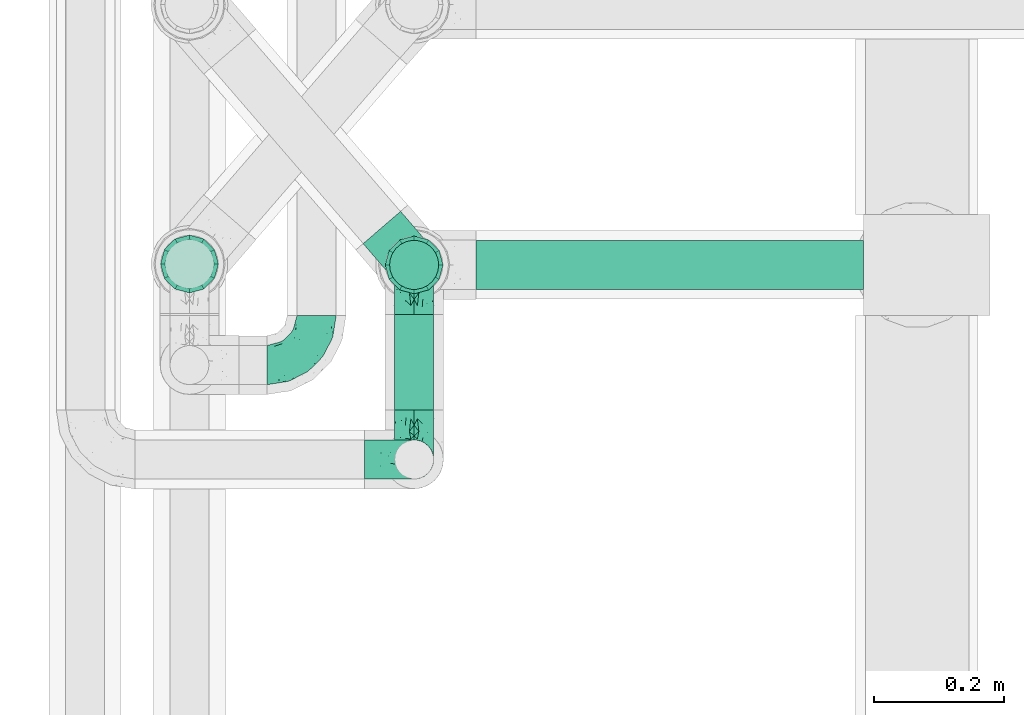
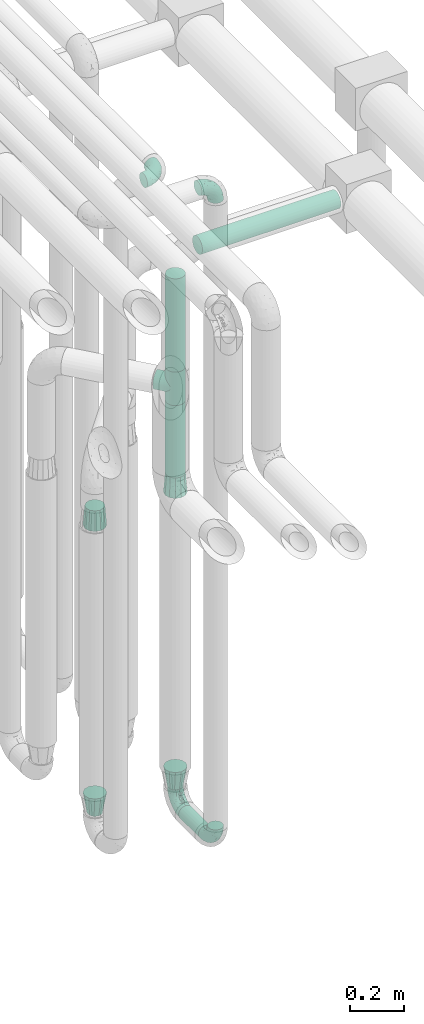
# One storey, part 608 of 827: 9 flow fittings, 4 flow segments.
"""IFC2X3 building model written with IfcOpenShell, lengths in millimetres."""

from ifc_helpers import new_model, entity, si_unit, converted_unit, derived_unit, direction, frame, origin, origin_2d_with_axis, place, context, subcontext, project, spatial, circle, extrude, faceted_brep, source, transform, mapped, material, type_object, type_shapes, element, save


model = new_model("IFC2X3")

# Units and contexts
model_context = context("Model", 3, precision=0.01, world=origin(), true_north=direction((6.12303176911189e-17, 1.0)))
body_context = subcontext(model_context, "Body", "Model", "MODEL_VIEW")
ifc_project = project(units=[si_unit("LENGTHUNIT", "METRE", prefix="MILLI"), si_unit("AREAUNIT", "SQUARE_METRE"), si_unit("VOLUMEUNIT", "CUBIC_METRE"), converted_unit("PLANEANGLEUNIT", "DEGREE", entity("IfcRatioMeasure", 0.0174532925199433), si_unit("PLANEANGLEUNIT", "RADIAN"), dimensions=[0, 0, 0, 0, 0, 0, 0]), si_unit("MASSUNIT", "GRAM", prefix="KILO"), derived_unit("MASSDENSITYUNIT", [(si_unit("MASSUNIT", "GRAM", prefix="KILO"), 1), (si_unit("LENGTHUNIT", "METRE"), -3)]), derived_unit("MOMENTOFINERTIAUNIT", [(si_unit("LENGTHUNIT", "METRE"), 4)]), si_unit("TIMEUNIT", "SECOND"), si_unit("FREQUENCYUNIT", "HERTZ"), si_unit("THERMODYNAMICTEMPERATUREUNIT", "DEGREE_CELSIUS"), derived_unit("THERMALTRANSMITTANCEUNIT", [(si_unit("MASSUNIT", "GRAM", prefix="KILO"), 1), (si_unit("THERMODYNAMICTEMPERATUREUNIT", "KELVIN"), -1), (si_unit("TIMEUNIT", "SECOND"), -3)]), derived_unit("VOLUMETRICFLOWRATEUNIT", [(si_unit("LENGTHUNIT", "METRE"), 3), (si_unit("TIMEUNIT", "SECOND"), -1)]), derived_unit("MASSFLOWRATEUNIT", [(si_unit("MASSUNIT", "GRAM", prefix="KILO"), 1), (si_unit("TIMEUNIT", "SECOND"), -1)]), derived_unit("ROTATIONALFREQUENCYUNIT", [(si_unit("TIMEUNIT", "SECOND"), -1)]), si_unit("ELECTRICCURRENTUNIT", "AMPERE"), si_unit("ELECTRICVOLTAGEUNIT", "VOLT"), si_unit("POWERUNIT", "WATT"), si_unit("FORCEUNIT", "NEWTON", prefix="KILO"), si_unit("ILLUMINANCEUNIT", "LUX"), si_unit("LUMINOUSFLUXUNIT", "LUMEN"), si_unit("LUMINOUSINTENSITYUNIT", "CANDELA"), derived_unit("USERDEFINED", [(si_unit("MASSUNIT", "GRAM", prefix="KILO"), -1), (si_unit("LENGTHUNIT", "METRE"), -2), (si_unit("TIMEUNIT", "SECOND"), 3), (si_unit("LUMINOUSFLUXUNIT", "LUMEN"), 1)]), derived_unit("LINEARVELOCITYUNIT", [(si_unit("LENGTHUNIT", "METRE"), 1), (si_unit("TIMEUNIT", "SECOND"), -1)]), si_unit("PRESSUREUNIT", "PASCAL"), derived_unit("USERDEFINED", [(si_unit("LENGTHUNIT", "METRE"), -2), (si_unit("MASSUNIT", "GRAM", prefix="KILO"), 1), (si_unit("TIMEUNIT", "SECOND"), -2)]), derived_unit("LINEARFORCEUNIT", [(si_unit("MASSUNIT", "GRAM", prefix="KILO"), 1), (si_unit("LENGTHUNIT", "METRE"), 1), (si_unit("TIMEUNIT", "SECOND"), -2), (si_unit("LENGTHUNIT", "METRE"), -1)]), derived_unit("PLANARFORCEUNIT", [(si_unit("MASSUNIT", "GRAM", prefix="KILO"), 1), (si_unit("LENGTHUNIT", "METRE"), 1), (si_unit("TIMEUNIT", "SECOND"), -2), (si_unit("LENGTHUNIT", "METRE"), -2)])], contexts=[model_context])

# Site, building, storey
site_placement = place(None, origin())
site = spatial("IfcSite", under=ifc_project, at=site_placement, CompositionType="ELEMENT")
building_placement = place(site_placement, origin())
building = spatial("IfcBuilding", under=site, at=building_placement, CompositionType="ELEMENT")
storey_placement = place(building_placement, frame((0.0, 0.0, 28200.0)))
storey = spatial("IfcBuildingStorey", under=building, at=storey_placement, Name="08", CompositionType="ELEMENT", Elevation=28200.0)

# Flow segments
pipe_segment_type = type_object("IfcPipeSegmentType", PredefinedType="NOTDEFINED")
flow_segment_1_placement = place(storey_placement, frame((36943.44, 9857.02, 368.4)))
element("IfcFlowSegment", 1, at=flow_segment_1_placement, inside=storey, type_object=pipe_segment_type, context=body_context, shape_type="SweptSolid", body=[
    extrude(circle(Radius=30.0, at=origin_2d_with_axis()), frame((31.6, 0.0, 31.6), z_axis=(0.0, 1.0, 0.0), x_axis=(1.0, 0.0, 0.0)), (0.0, 0.0, 1.0), 147.178757185185),
])
flow_segment_2_placement = place(storey_placement, frame((36935.69, 10040.86, 2381.0)))
element("IfcFlowSegment", 2, at=flow_segment_2_placement, inside=storey, type_object=pipe_segment_type, context=body_context, shape_type="SweptSolid", body=[
    extrude(circle(Radius=37.75, at=origin_2d_with_axis()), frame((39.35, 39.35, 0.0), z_axis=(-1.10186210596573e-06, 1.69450659785389e-07, 1.0), x_axis=(-1.0, 0.0, -1.10186210596575e-06)), (0.0, 0.0, 1.0), 423.904960792813),
])
flow_segment_3_placement = place(storey_placement, frame((37070.03, 10040.86, 2860.56)))
element("IfcFlowSegment", 3, at=flow_segment_3_placement, inside=storey, type_object=pipe_segment_type, context=body_context, shape_type="SweptSolid", body=[
    extrude(circle(Radius=37.75, at=origin_2d_with_axis()), frame((0.0, 39.35, 39.35), z_axis=(1.0, 0.0, 0.0), x_axis=(0.0, 1.0, 0.0)), (0.0, 0.0, 1.0), 595.765844455015),
])
flow_segment_4_placement = place(storey_placement, frame((36935.69, 10040.86, 1900.0)))
element("IfcFlowSegment", 4, at=flow_segment_4_placement, inside=storey, type_object=pipe_segment_type, context=body_context, shape_type="SweptSolid", body=[
    extrude(circle(Radius=37.75, at=origin_2d_with_axis()), frame((39.35, 39.35, 0.0), z_axis=(0.0, 0.0, 1.0), x_axis=(-1.0, 0.0, 0.0)), (0.0, 0.0, 1.0), 328.999999999994),
])

# Flow fittings
ifc_material = material()
pipe_fitting_type_1 = type_object("IfcPipeFittingType", Name="ADSK_1", PredefinedType="NOTDEFINED", material=ifc_material)
shared_shape_1 = source(origin(), body_context, "Body", "Brep", [
    faceted_brep([(-76.0, 15.07, -26.11), (-76.0, 7.8, -29.12), (-76.0, 0.0, -30.15), (-76.0, -7.8, -29.12), (-76.0, -15.08, -26.11), (-76.0, -21.32, -21.32), (-76.0, -26.11, -15.08), (-76.0, -29.12, -7.8), (-76.0, -30.15, 0.0), (-76.0, -29.12, 7.8), (-76.0, -26.11, 15.07), (-76.0, -21.32, 21.32), (-76.0, -15.08, 26.11), (-76.0, -7.8, 29.12), (-76.0, 0.0, 30.15), (-76.0, 7.8, 29.12), (-76.0, 15.07, 26.11), (-76.0, 21.32, 21.32), (-76.0, 26.11, 15.07), (-76.0, 29.12, 7.8), (-76.0, 30.15, 0.0), (-76.0, 29.12, -7.8), (-76.0, 26.11, -15.08), (-76.0, 21.32, -21.32), (0.0, 76.0, -30.15), (-7.8, 76.0, -29.12), (-15.07, 76.0, -26.11), (-21.32, 76.0, -21.32), (-26.11, 76.0, -15.08), (-29.12, 76.0, -7.8), (-30.15, 76.0, 0.0), (-29.12, 76.0, 7.8), (-26.11, 76.0, 15.07), (-21.32, 76.0, 21.32), (-15.07, 76.0, 26.11), (-7.8, 76.0, 29.12), (0.0, 76.0, 30.15), (7.8, 76.0, 29.12), (15.08, 76.0, 26.11), (21.32, 76.0, 21.32), (26.11, 76.0, 15.07), (29.12, 76.0, 7.8), (30.15, 76.0, 0.0), (29.12, 76.0, -7.8), (26.11, 76.0, -15.08), (21.32, 76.0, -21.32), (15.08, 76.0, -26.11), (7.8, 76.0, -29.12), (10.79, 31.43, 21.07), (4.32, 31.7, 25.72), (1.65, 15.19, 19.92), (-61.17, -27.8, 0.0), (-51.1, -25.49, 9.84), (-56.14, -10.61, 27.27), (-31.7, -4.32, 25.72), (-39.75, 1.72, 29.41), (-43.2, -24.95, 0.0), (-1.86, 1.86, 0.0), (4.49, 7.65, 5.78), (-7.82, -4.61, 5.83), (-56.21, -22.79, 17.21), (-58.98, -3.38, 29.7), (-53.96, 5.6, 30.07), (-10.86, 10.86, 25.48), (-17.2, -2.6, 20.44), (-49.15, -16.01, 22.7), (-22.18, -14.24, 7.99), (-28.4, -17.42, 0.0), (-13.61, -9.88, 0.0), (-39.0, 23.48, 27.76), (-58.76, 12.54, 28.36), (-41.61, 15.41, 29.48), (16.01, 49.15, 22.7), (-58.55, 25.93, 19.53), (-51.53, 33.5, 13.51), (-64.92, 28.76, 12.4), (-7.48, 23.14, 28.25), (-1.72, 39.75, 29.41), (-12.04, 27.88, 29.88), (-63.91, 18.81, 24.52), (-11.63, 65.16, 28.18), (-4.97, 57.02, 30.05), (9.88, 13.61, 0.0), (-62.5, 31.74, 5.02), (-45.17, 30.98, 21.2), (-21.78, 9.76, 28.58), (10.61, 56.14, 27.27), (-32.09, 54.42, 13.26), (22.79, 56.21, 17.21), (15.38, 31.17, 15.63), (25.49, 51.1, 9.84), (21.84, 36.35, 5.92), (24.95, 43.2, 0.0), (3.38, 58.98, 29.7), (-31.17, -15.38, 15.63), (-39.39, 41.78, 15.45), (-34.56, 41.13, 20.79), (-39.81, -23.25, 5.49), (27.8, 61.17, 0.0), (-31.74, 62.5, 5.02), (-53.07, 36.29, 0.0), (-42.95, 42.95, 7.29), (-36.29, 53.07, 0.0), (-19.83, 58.51, 24.79), (-25.48, 60.2, 19.41), (-14.53, 50.96, 28.57), (-13.31, 37.09, 30.07), (-26.16, 40.06, 26.4), (-32.43, -10.35, 21.9), (17.42, 28.4, 0.0), (14.24, 22.18, 7.99), (-38.67, 9.72, 30.15), (-24.66, 17.36, 30.09), (-37.08, 31.49, 24.99), (-49.27, 22.83, 25.24), (-20.8, 38.81, 28.63), (-27.58, 27.58, 29.2), (-36.07, -20.23, 10.71), (-15.19, -6.16, 14.9), (6.6, 15.4, 14.49), (-2.51, 2.51, 11.35), (-65.16, 11.63, -28.18), (-49.15, -16.01, -22.7), (-57.02, 4.97, -30.05), (-25.93, 58.55, -19.53), (-33.5, 51.53, -13.51), (-28.76, 64.92, -12.4), (-60.2, 25.48, -19.41), (-58.51, 19.83, -24.79), (4.61, 7.82, -5.83), (-7.65, -4.49, -5.78), (-2.51, 2.51, -11.35), (-62.5, 31.74, -5.02), (-50.96, 14.53, -28.57), (-37.09, 13.31, -30.07), (-42.95, 42.95, -7.29), (25.49, 51.1, -9.84), (22.79, 56.21, -17.21), (-40.06, 26.16, -26.4), (3.38, 58.98, -29.7), (-5.6, 53.96, -30.07), (-27.88, 12.04, -29.88), (-9.76, 21.78, -28.58), (-23.14, 7.48, -28.25), (-51.1, -25.49, -9.84), (15.38, 31.17, -15.63), (16.01, 49.15, -22.7), (-23.48, 39.0, -27.76), (-12.54, 58.76, -28.36), (-15.41, 41.61, -29.48), (-56.21, -22.79, -17.21), (-9.72, 38.67, -30.15), (-17.36, 24.66, -30.09), (-22.18, -14.24, -7.99), (-41.13, 34.56, -20.79), (-31.74, 62.5, -5.02), (-58.98, -3.38, -29.7), (-31.17, -15.38, -15.63), (-56.14, -10.61, -27.27), (14.24, 22.18, -7.99), (23.25, 39.81, -5.49), (-31.49, 37.08, -24.99), (-15.19, -6.16, -14.9), (1.65, 15.19, -19.92), (-18.81, 63.91, -24.52), (-32.59, -11.62, -20.84), (-31.7, -4.32, -25.72), (-17.2, -2.6, -20.44), (-39.75, 1.72, -29.41), (-54.42, 32.09, -13.26), (-30.98, 45.17, -21.2), (10.61, 56.14, -27.27), (10.23, 31.31, -21.52), (4.32, 31.7, -25.72), (-41.78, 39.39, -15.45), (-1.72, 39.75, -29.41), (-36.35, -21.84, -5.92), (-22.83, 49.27, -25.24), (-38.81, 20.8, -28.63), (-27.58, 27.58, -29.2), (-10.86, 10.86, -25.48), (20.23, 36.07, -10.71), (6.6, 15.4, -14.49)], [[[0, 1, 2, 3, 4, 5, 6, 7, 8, 9, 10, 11, 12, 13, 14, 15, 16, 17, 18, 19, 20, 21, 22, 23]], [[24, 25, 26, 27, 28, 29, 30, 31, 32, 33, 34, 35, 36, 37, 38, 39, 40, 41, 42, 43, 44, 45, 46, 47]], [[48, 49, 50]], [[51, 52, 9]], [[53, 54, 55]], [[9, 52, 10]], [[56, 52, 51]], [[57, 58, 59]], [[11, 10, 60]], [[14, 61, 62]], [[63, 54, 64]], [[65, 12, 11]], [[65, 53, 12]], [[66, 67, 68]], [[69, 70, 71]], [[72, 39, 38]], [[73, 74, 75]], [[15, 70, 16]], [[76, 77, 78]], [[16, 79, 17]], [[13, 61, 14]], [[35, 80, 81]], [[14, 62, 15]], [[17, 73, 18]], [[57, 82, 58]], [[20, 19, 83]], [[75, 19, 18]], [[70, 15, 62]], [[73, 84, 74]], [[78, 85, 76]], [[38, 86, 72]], [[32, 31, 87]], [[88, 89, 90]], [[91, 92, 90]], [[72, 86, 49]], [[36, 93, 37]], [[75, 83, 19]], [[36, 35, 81]], [[60, 94, 65]], [[40, 90, 41]], [[95, 96, 87]], [[88, 90, 40]], [[66, 97, 67]], [[90, 98, 41]], [[40, 39, 88]], [[99, 31, 30]], [[20, 83, 100]], [[101, 102, 100]], [[52, 60, 10]], [[102, 99, 30]], [[96, 103, 104]], [[83, 101, 100]], [[12, 53, 13]], [[104, 103, 33]], [[105, 106, 81]], [[107, 105, 103]], [[64, 54, 108]], [[80, 103, 105]], [[80, 35, 34]], [[34, 33, 103]], [[86, 38, 37]], [[109, 110, 82]], [[71, 111, 112]], [[69, 107, 113]], [[79, 73, 17]], [[114, 113, 84]], [[33, 32, 104]], [[115, 107, 116]], [[105, 115, 106]], [[93, 81, 77]], [[54, 53, 65]], [[61, 53, 55]], [[108, 94, 64]], [[54, 63, 85]], [[93, 86, 37]], [[77, 76, 49]], [[77, 49, 86]], [[49, 63, 50]], [[60, 52, 117]], [[65, 11, 60]], [[39, 72, 88]], [[89, 88, 72]], [[71, 70, 62]], [[79, 70, 114]], [[103, 96, 107]], [[69, 113, 114]], [[112, 106, 116]], [[77, 81, 106]], [[112, 116, 71]], [[112, 55, 85]], [[64, 50, 63]], [[57, 59, 68]], [[32, 87, 104]], [[96, 104, 87]], [[94, 118, 64]], [[50, 119, 89]], [[50, 64, 118]], [[50, 89, 48]], [[81, 93, 36]], [[86, 93, 77]], [[53, 61, 13]], [[62, 61, 55]], [[71, 62, 111]], [[69, 71, 116]], [[95, 101, 74]], [[99, 101, 87]], [[118, 66, 59]], [[117, 97, 66]], [[117, 66, 94]], [[91, 89, 110]], [[91, 110, 109]], [[110, 89, 119]], [[9, 8, 51]], [[98, 90, 92]], [[98, 42, 41]], [[101, 83, 74]], [[101, 99, 102]], [[87, 31, 99]], [[62, 55, 111]], [[55, 112, 111]], [[107, 69, 116]], [[70, 69, 114]], [[107, 96, 113]], [[84, 113, 96]], [[84, 96, 95]], [[114, 84, 73]], [[70, 79, 16]], [[73, 79, 114]], [[54, 85, 55]], [[76, 85, 63]], [[49, 76, 63]], [[77, 106, 78]], [[106, 112, 78]], [[85, 78, 112]], [[73, 75, 18]], [[83, 75, 74]], [[103, 80, 34]], [[81, 80, 105]], [[101, 95, 87]], [[84, 95, 74]], [[106, 115, 116]], [[105, 107, 115]], [[120, 59, 58]], [[82, 110, 58]], [[119, 58, 110]], [[118, 59, 120]], [[66, 68, 59]], [[54, 65, 108]], [[94, 108, 65]], [[66, 118, 94]], [[50, 118, 120]], [[50, 120, 119]], [[119, 120, 58]], [[89, 72, 48]], [[49, 48, 72]], [[60, 117, 94]], [[117, 52, 97]], [[52, 56, 97]], [[67, 97, 56]], [[92, 91, 109]], [[89, 91, 90]], [[121, 1, 0]], [[122, 5, 4]], [[2, 1, 123]], [[124, 125, 126]], [[127, 128, 23]], [[129, 130, 131]], [[100, 132, 20]], [[133, 134, 123]], [[135, 100, 102]], [[136, 137, 44]], [[133, 128, 138]], [[24, 139, 140]], [[141, 142, 143]], [[121, 128, 133]], [[6, 144, 7]], [[137, 145, 146]], [[144, 51, 7]], [[147, 148, 149]], [[144, 6, 150]], [[149, 151, 152]], [[153, 68, 67]], [[154, 128, 127]], [[30, 155, 102]], [[43, 42, 98]], [[156, 3, 2]], [[157, 144, 150]], [[158, 4, 3]], [[24, 140, 25]], [[155, 135, 102]], [[159, 160, 109]], [[30, 29, 155]], [[147, 138, 161]], [[27, 124, 28]], [[57, 129, 82]], [[162, 163, 131]], [[27, 26, 164]], [[148, 26, 25]], [[165, 166, 167]], [[24, 47, 139]], [[143, 168, 141]], [[22, 21, 169]], [[125, 124, 170]], [[148, 25, 140]], [[46, 146, 171]], [[158, 122, 4]], [[0, 23, 128]], [[1, 121, 123]], [[109, 82, 159]], [[45, 44, 137]], [[146, 46, 45]], [[136, 43, 98]], [[132, 21, 20]], [[136, 98, 92]], [[172, 173, 146]], [[46, 171, 47]], [[43, 136, 44]], [[174, 154, 169]], [[171, 173, 175]], [[6, 5, 150]], [[126, 29, 28]], [[176, 56, 144]], [[122, 158, 166]], [[164, 124, 27]], [[177, 161, 170]], [[23, 22, 127]], [[178, 138, 179]], [[133, 178, 134]], [[156, 123, 168]], [[156, 158, 3]], [[168, 143, 166]], [[168, 166, 158]], [[166, 180, 167]], [[173, 171, 146]], [[139, 171, 175]], [[172, 145, 163]], [[173, 180, 142]], [[5, 122, 150]], [[157, 150, 122]], [[137, 136, 181]], [[146, 45, 137]], [[149, 148, 140]], [[164, 148, 177]], [[128, 154, 138]], [[147, 161, 177]], [[152, 134, 179]], [[168, 123, 134]], [[152, 179, 149]], [[152, 175, 142]], [[57, 130, 129]], [[157, 165, 167]], [[22, 169, 127]], [[154, 127, 169]], [[163, 167, 180]], [[162, 157, 167]], [[173, 163, 180]], [[182, 163, 145]], [[123, 156, 2]], [[158, 156, 168]], [[171, 139, 47]], [[140, 139, 175]], [[149, 140, 151]], [[147, 149, 179]], [[174, 135, 125]], [[132, 135, 169]], [[176, 157, 153]], [[176, 153, 67]], [[153, 157, 162]], [[182, 159, 129]], [[181, 160, 159]], [[181, 159, 145]], [[51, 144, 56]], [[51, 8, 7]], [[135, 132, 100]], [[169, 21, 132]], [[126, 155, 29]], [[135, 155, 125]], [[140, 175, 151]], [[175, 152, 151]], [[138, 147, 179]], [[148, 147, 177]], [[138, 154, 161]], [[170, 161, 154]], [[170, 154, 174]], [[177, 170, 124]], [[148, 164, 26]], [[124, 164, 177]], [[173, 142, 175]], [[143, 142, 180]], [[166, 143, 180]], [[168, 134, 141]], [[134, 152, 141]], [[142, 141, 152]], [[124, 126, 28]], [[155, 126, 125]], [[128, 121, 0]], [[123, 121, 133]], [[135, 174, 169]], [[170, 174, 125]], [[134, 178, 179]], [[133, 138, 178]], [[130, 153, 162]], [[68, 153, 130]], [[57, 68, 130]], [[182, 129, 131]], [[159, 82, 129]], [[157, 122, 165]], [[166, 165, 122]], [[163, 162, 167]], [[162, 131, 130]], [[145, 172, 146]], [[163, 173, 172]], [[159, 182, 145]], [[131, 163, 182]], [[56, 176, 67]], [[157, 176, 144]], [[137, 181, 145]], [[181, 136, 160]], [[136, 92, 160]], [[109, 160, 92]]]),
])
type_shapes(pipe_fitting_type_1, [shared_shape_1])
flow_fitting_1_placement = place(storey_placement, frame((36825.03, 9926.17, 3400.0)))
element("IfcFlowFitting", 5, at=flow_fitting_1_placement, inside=storey, type_object=pipe_fitting_type_1, material=ifc_material, Name="ADSK_1", ObjectType="ADSK_1", context=body_context, shape_type="MappedRepresentation", body=[
    mapped(shared_shape_1, transform((0.0, 0.0, 0.0), scale=1.0)),
])
for number, where, z_axis, x_axis, name in (
    (6, (36975.03, 9781.02, 400.0), (-1.0, 0.0, 0.0), (0.0, -1.0, 0.0), "ADSK_1"),
    (7, (36975.03, 9781.02, 3400.0), (0.0, -1.0, 0.0), (0.0, 0.0, 1.0), "ADSK_1"),
    (8, (36975.03, 10080.2, 400.0), (1.0, 0.0, 0.0), (0.0, 1.0, 0.0), "ADSK_1"),
):
    element("IfcFlowFitting", number, at=place(storey_placement, frame(where, z_axis=z_axis, x_axis=x_axis)), inside=storey, type_object=pipe_fitting_type_1, material=ifc_material, Name=name, ObjectType="ADSK_1", context=body_context, shape_type="MappedRepresentation", body=[
        mapped(shared_shape_1, transform((0.0, 0.0, 0.0), scale=1.0)),
    ])
pipe_fitting_type_2 = type_object("IfcPipeFittingType", Name="ADSK_1", PredefinedType="NOTDEFINED", material=ifc_material)
shared_shape_2 = source(origin(), body_context, "Body", "Brep", [
    faceted_brep([(-76.0, 9.85, -36.75), (-76.0, 0.0, -38.05), (-76.0, -9.85, -36.75), (-76.0, -19.03, -32.95), (-76.0, -22.97, -29.93), (-76.0, -26.91, -26.91), (-76.0, -29.93, -22.97), (-76.0, -32.95, -19.03), (-76.0, -34.85, -14.44), (-76.0, -36.75, -9.85), (-76.0, -38.05, 0.0), (-76.0, -36.75, 9.85), (-76.0, -34.85, 14.44), (-76.0, -32.95, 19.02), (-76.0, -29.93, 22.97), (-76.0, -26.91, 26.91), (-76.0, -22.97, 29.93), (-76.0, -19.03, 32.95), (-76.0, -9.85, 36.75), (-76.0, 0.0, 38.05), (-76.0, 9.85, 36.75), (-76.0, 19.02, 32.95), (-76.0, 26.91, 26.91), (-76.0, 32.95, 19.02), (-76.0, 36.75, 9.85), (-76.0, 38.05, 0.0), (-76.0, 36.75, -9.85), (-76.0, 32.95, -19.03), (-76.0, 26.91, -26.91), (-76.0, 19.02, -32.95), (76.0, 26.91, -26.91), (76.0, 32.95, -19.03), (76.0, 36.75, -9.85), (76.0, 38.05, 0.0), (76.0, 36.75, 9.85), (76.0, 32.95, 19.02), (76.0, 26.91, 26.91), (76.0, 19.02, 32.95), (76.0, 9.85, 36.75), (76.0, 0.0, 38.05), (76.0, -9.85, 36.75), (76.0, -19.03, 32.95), (76.0, -22.97, 29.93), (76.0, -26.91, 26.91), (76.0, -29.93, 22.97), (76.0, -32.95, 19.02), (76.0, -34.85, 14.44), (76.0, -36.75, 9.85), (76.0, -38.05, 0.0), (76.0, -36.75, -9.85), (76.0, -34.85, -14.44), (76.0, -32.95, -19.03), (76.0, -29.93, -22.97), (76.0, -26.91, -26.91), (76.0, -22.97, -29.93), (76.0, -19.03, -32.95), (76.0, -9.85, -36.75), (76.0, 0.0, -38.05), (76.0, 9.85, -36.75), (76.0, 19.02, -32.95), (36.99, -36.99, 8.94), (38.05, -38.05, 0.0), (-36.99, -36.99, 8.94), (-38.05, -38.05, 0.0), (35.51, -35.51, 12.97), (34.04, -34.04, 17.0), (18.81, -18.81, 33.08), (29.74, -29.74, 23.73), (24.56, -24.56, 29.06), (-35.51, -35.51, 12.97), (-34.04, -34.04, 17.0), (-18.81, -18.81, 33.08), (-29.74, -29.74, 23.73), (-24.56, -24.56, 29.06), (-12.7, -12.7, 35.87), (6.4, -6.4, 37.51), (12.7, -12.7, 35.87), (0.0, 0.0, 38.05), (-6.4, -6.4, 37.51), (6.4, -6.4, -37.51), (0.0, 0.0, -38.05), (12.7, -12.7, -35.87), (-24.56, -24.56, -29.06), (-6.4, -6.4, -37.51), (-35.51, -35.51, -12.97), (-36.99, -36.99, -8.94), (-29.74, -29.74, -23.73), (-12.7, -12.7, -35.87), (18.81, -18.81, -33.08), (24.56, -24.56, -29.06), (-34.04, -34.04, -17.0), (29.74, -29.74, -23.73), (36.99, -36.99, -8.94), (35.51, -35.51, -12.97), (34.04, -34.04, -17.0), (-18.81, -18.81, -33.08), (9.85, -76.0, -36.75), (19.03, -76.0, -32.95), (26.91, -76.0, -26.91), (32.95, -76.0, -19.03), (36.75, -76.0, -9.85), (38.05, -76.0, 0.0), (36.75, -76.0, 9.85), (32.95, -76.0, 19.02), (26.91, -76.0, 26.91), (19.03, -76.0, 32.95), (9.85, -76.0, 36.75), (0.0, -76.0, 38.05), (-9.85, -76.0, 36.75), (-19.02, -76.0, 32.95), (-26.91, -76.0, 26.91), (-32.95, -76.0, 19.02), (-36.75, -76.0, 9.85), (-38.05, -76.0, 0.0), (-36.75, -76.0, -9.85), (-32.95, -76.0, -19.03), (-26.91, -76.0, -26.91), (-19.02, -76.0, -32.95), (-9.85, -76.0, -36.75), (0.0, -76.0, -38.05)], [[[0, 1, 2, 3, 4, 5, 6, 7, 8, 9, 10, 11, 12, 13, 14, 15, 16, 17, 18, 19, 20, 21, 22, 23, 24, 25, 26, 27, 28, 29]], [[30, 31, 32, 33, 34, 35, 36, 37, 38, 39, 40, 41, 42, 43, 44, 45, 46, 47, 48, 49, 50, 51, 52, 53, 54, 55, 56, 57, 58, 59]], [[48, 47, 60]], [[60, 61, 48]], [[62, 10, 63]], [[47, 46, 64]], [[46, 45, 65]], [[41, 66, 42]], [[43, 67, 45, 44]], [[67, 43, 68]], [[45, 67, 65]], [[68, 43, 42]], [[11, 69, 12]], [[70, 12, 69]], [[10, 62, 11]], [[11, 62, 69]], [[71, 17, 16]], [[72, 73, 15]], [[72, 15, 14, 13]], [[15, 73, 16]], [[71, 74, 17]], [[72, 13, 70]], [[46, 65, 64]], [[42, 66, 68]], [[40, 39, 75]], [[47, 64, 60]], [[66, 41, 76]], [[75, 76, 40]], [[75, 39, 77]], [[78, 77, 19]], [[76, 41, 40]], [[23, 22, 36, 35]], [[24, 23, 35, 34]], [[21, 20, 38, 37]], [[22, 21, 37, 36]], [[38, 20, 19, 77, 39]], [[25, 24, 34, 33]], [[70, 13, 12]], [[78, 18, 74]], [[18, 78, 19]], [[18, 17, 74]], [[71, 16, 73]], [[28, 27, 31, 30]], [[26, 32, 31, 27]], [[25, 33, 32, 26]], [[29, 28, 30, 59]], [[57, 56, 79]], [[58, 57, 80, 1, 0]], [[79, 56, 81]], [[82, 5, 4]], [[59, 58, 0, 29]], [[56, 55, 81]], [[57, 79, 80]], [[80, 83, 1]], [[9, 84, 85]], [[86, 7, 6, 5]], [[83, 87, 2]], [[1, 83, 2]], [[87, 3, 2]], [[88, 54, 89]], [[54, 53, 89]], [[8, 90, 84]], [[88, 55, 54]], [[91, 89, 53]], [[52, 51, 91, 53]], [[55, 88, 81]], [[49, 92, 93]], [[92, 49, 48]], [[94, 50, 93]], [[61, 92, 48]], [[85, 63, 10]], [[51, 94, 91]], [[82, 4, 95]], [[49, 93, 50]], [[4, 3, 95]], [[5, 82, 86]], [[94, 51, 50]], [[95, 3, 87]], [[9, 8, 84]], [[90, 8, 7]], [[9, 85, 10]], [[90, 7, 86]], [[96, 97, 98, 99, 100, 101, 102, 103, 104, 105, 106, 107, 108, 109, 110, 111, 112, 113, 114, 115, 116, 117, 118, 119]], [[62, 63, 113]], [[112, 62, 113]], [[110, 109, 73]], [[72, 111, 110]], [[70, 112, 111]], [[74, 109, 108]], [[112, 70, 69, 62]], [[73, 72, 110]], [[70, 111, 72]], [[74, 71, 109]], [[107, 77, 78]], [[74, 108, 78]], [[73, 109, 71]], [[78, 108, 107]], [[75, 107, 106]], [[105, 76, 106]], [[103, 102, 65]], [[67, 104, 103]], [[68, 105, 104]], [[60, 102, 101]], [[68, 66, 105]], [[76, 75, 106]], [[66, 76, 105]], [[61, 60, 101]], [[65, 67, 103]], [[102, 60, 64, 65]], [[68, 104, 67]], [[107, 75, 77]], [[61, 101, 92]], [[100, 92, 101]], [[98, 97, 89]], [[94, 100, 99]], [[98, 91, 99]], [[81, 97, 96]], [[100, 94, 93, 92]], [[89, 91, 98]], [[94, 99, 91]], [[81, 88, 97]], [[119, 80, 79]], [[81, 96, 79]], [[89, 97, 88]], [[79, 96, 119]], [[83, 119, 118]], [[117, 87, 118]], [[115, 114, 90]], [[86, 116, 115]], [[82, 117, 116]], [[85, 114, 113]], [[82, 95, 117]], [[87, 83, 118]], [[95, 87, 117]], [[63, 85, 113]], [[90, 86, 115]], [[114, 85, 84, 90]], [[82, 116, 86]], [[119, 83, 80]]]),
])
type_shapes(pipe_fitting_type_2, [shared_shape_2])
flow_fitting_2_placement = place(storey_placement, frame((36975.03, 10080.2, 2305.0), z_axis=(0.757098240256198, 0.653301044389926, 0.0), x_axis=(0.0, 0.0, 1.0)))
element("IfcFlowFitting", 9, at=flow_fitting_2_placement, inside=storey, type_object=pipe_fitting_type_2, material=ifc_material, Name="ADSK_1", ObjectType="ADSK_1", context=body_context, shape_type="MappedRepresentation", body=[
    mapped(shared_shape_2, transform((0.0, 0.0, 0.0), scale=1.0)),
])
pipe_fitting_type_3 = type_object("IfcPipeFittingType", Name="ADSK_1", PredefinedType="NOTDEFINED", material=ifc_material)
shared_shape_3 = source(origin(), body_context, "Body", "Brep", [
    faceted_brep([(89.0, -44.45, 0.0), (89.0, -41.96, -9.31), (89.0, -38.49, -22.22), (89.0, -30.36, -30.36), (89.0, -22.23, -38.49), (89.0, -11.11, -41.47), (89.0, 0.0, -44.45), (89.0, 11.11, -41.47), (89.0, 22.22, -38.49), (89.0, 30.36, -30.36), (89.0, 38.49, -22.22), (89.0, 41.96, -9.31), (89.0, 44.45, 0.0), (89.0, 41.96, 9.31), (89.0, 38.49, 22.23), (89.0, 30.36, 30.36), (89.0, 22.22, 38.49), (89.0, 11.11, 41.47), (89.0, 0.0, 44.45), (89.0, -11.11, 41.47), (89.0, -22.23, 38.49), (89.0, -30.36, 30.36), (89.0, -38.49, 22.23), (89.0, -41.96, 9.31), (0.0, 38.05, 0.0), (0.0, 35.5, -9.51), (0.0, 32.95, -19.02), (0.0, 25.99, -25.99), (0.0, 19.02, -32.95), (0.0, 9.51, -35.5), (0.0, 0.0, -38.05), (0.0, -9.51, -35.5), (0.0, -19.03, -32.95), (0.0, -25.99, -25.99), (0.0, -32.95, -19.02), (0.0, -35.5, -9.51), (0.0, -38.05, 0.0), (0.0, -35.5, 9.51), (0.0, -32.95, 19.03), (0.0, -25.99, 25.99), (0.0, -19.03, 32.95), (0.0, -9.51, 35.5), (0.0, 0.0, 38.05), (0.0, 9.51, 35.5), (0.0, 19.03, 32.95), (0.0, 25.99, 25.99), (0.0, 32.95, 19.03), (0.0, 35.5, 9.51)], [[[0, 1, 2, 3, 4, 5, 6, 7, 8, 9, 10, 11, 12, 13, 14, 15, 16, 17, 18, 19, 20, 21, 22, 23]], [[24, 25, 26, 27, 28, 29, 30, 31, 32, 33, 34, 35, 36, 37, 38, 39, 40, 41, 42, 43, 44, 45, 46, 47]], [[2, 1, 0, 36, 35, 34]], [[28, 8, 7, 6, 30, 29]], [[32, 4, 3, 2, 34, 33]], [[5, 4, 32, 31, 30, 6]], [[10, 26, 25, 24, 12, 11]], [[9, 8, 28, 27, 26, 10]], [[14, 13, 12, 24, 47, 46]], [[40, 20, 19, 18, 42, 41]], [[44, 16, 15, 14, 46, 45]], [[17, 16, 44, 43, 42, 18]], [[22, 38, 37, 36, 0, 23]], [[21, 20, 40, 39, 38, 22]]]),
])
type_shapes(pipe_fitting_type_3, [shared_shape_3])
flow_fitting_3_placement = place(storey_placement, frame((36629.64, 10081.59, 1870.0), z_axis=(0.0, 1.0, 0.0), x_axis=(0.0, 0.0, -1.0)))
element("IfcFlowFitting", 10, at=flow_fitting_3_placement, inside=storey, type_object=pipe_fitting_type_3, material=ifc_material, Name="ADSK_1", ObjectType="ADSK_1", context=body_context, shape_type="MappedRepresentation", body=[
    mapped(shared_shape_3, transform((0.0, 0.0, 0.0), scale=1.0)),
])
pipe_fitting_type_4 = type_object("IfcPipeFittingType", Name="ADSK_1", PredefinedType="NOTDEFINED", material=ifc_material)
shared_shape_4 = source(origin(), body_context, "Body", "Brep", [
    faceted_brep([(89.0, -44.45, 0.0), (89.0, -42.1, -8.76), (89.0, -38.49, -22.22), (89.0, -30.36, -30.36), (89.0, -22.23, -38.49), (89.0, -11.11, -41.47), (89.0, 0.0, -44.45), (89.0, 11.11, -41.47), (89.0, 22.22, -38.49), (89.0, 30.36, -30.36), (89.0, 38.49, -22.22), (89.0, 42.1, -8.76), (89.0, 44.45, 0.0), (89.0, 42.1, 8.76), (89.0, 38.49, 22.23), (89.0, 30.36, 30.36), (89.0, 22.22, 38.49), (89.0, 11.11, 41.47), (89.0, 0.0, 44.45), (89.0, -11.11, 41.47), (89.0, -22.23, 38.49), (89.0, -30.36, 30.36), (89.0, -38.49, 22.23), (89.0, -42.1, 8.76), (0.0, 30.15, 0.0), (0.0, 27.27, -8.86), (0.0, 24.39, -17.72), (0.0, 16.85, -23.2), (0.0, 9.32, -28.67), (0.0, 0.0, -28.67), (0.0, -9.32, -28.67), (0.0, -16.85, -23.2), (0.0, -24.39, -17.72), (0.0, -27.27, -8.86), (0.0, -30.15, 0.0), (0.0, -27.27, 8.86), (0.0, -24.39, 17.72), (0.0, -16.85, 23.2), (0.0, -9.32, 28.67), (0.0, 0.0, 28.67), (0.0, 9.32, 28.67), (0.0, 16.85, 23.2), (0.0, 24.39, 17.72), (0.0, 27.27, 8.86)], [[[0, 1, 2, 3, 4, 5, 6, 7, 8, 9, 10, 11, 12, 13, 14, 15, 16, 17, 18, 19, 20, 21, 22, 23]], [[24, 25, 26, 27, 28, 29, 30, 31, 32, 33, 34, 35, 36, 37, 38, 39, 40, 41, 42, 43]], [[2, 33, 32]], [[28, 7, 29]], [[29, 5, 30]], [[24, 12, 11]], [[3, 32, 31]], [[34, 1, 0]], [[1, 34, 33]], [[8, 28, 27]], [[2, 1, 33]], [[31, 4, 3]], [[2, 32, 3]], [[11, 25, 24]], [[26, 10, 9]], [[10, 25, 11]], [[28, 8, 7]], [[27, 26, 9]], [[26, 25, 10]], [[31, 30, 4]], [[8, 27, 9]], [[29, 7, 6]], [[5, 29, 6]], [[5, 4, 30]], [[14, 43, 42]], [[38, 19, 39]], [[39, 17, 40]], [[34, 0, 23]], [[15, 42, 41]], [[24, 13, 12]], [[13, 24, 43]], [[20, 38, 37]], [[14, 13, 43]], [[41, 16, 15]], [[14, 42, 15]], [[23, 35, 34]], [[36, 22, 21]], [[22, 35, 23]], [[38, 20, 19]], [[37, 36, 21]], [[36, 35, 22]], [[41, 40, 16]], [[20, 37, 21]], [[39, 19, 18]], [[17, 39, 18]], [[17, 16, 40]]]),
])
type_shapes(pipe_fitting_type_4, [shared_shape_4])
for number, where, z_axis, x_axis, name in (
    (11, (36975.03, 10080.2, 476.0), (1.0, 0.0, 0.0), (0.0, 0.0, 1.0), "ADSK_1"),
    (12, (36629.64, 10081.59, 476.0), (1.0, 0.0, 0.0), (0.0, 0.0, 1.0), "ADSK_1"),
):
    element("IfcFlowFitting", number, at=place(storey_placement, frame(where, z_axis=z_axis, x_axis=x_axis)), inside=storey, type_object=pipe_fitting_type_4, material=ifc_material, Name=name, ObjectType="ADSK_1", context=body_context, shape_type="MappedRepresentation", body=[
        mapped(shared_shape_4, transform((0.0, 0.0, 0.0), scale=1.0)),
    ])
pipe_fitting_type_5 = type_object("IfcPipeFittingType", Name="ADSK_1", PredefinedType="NOTDEFINED", material=ifc_material)
shared_shape_5 = source(origin(), body_context, "Body", "Brep", [
    faceted_brep([(89.0, 38.05, 0.0), (89.0, 35.5, 9.51), (89.0, 32.95, 19.03), (89.0, 25.99, 25.99), (89.0, 19.02, 32.95), (89.0, 9.51, 35.5), (89.0, 0.0, 38.05), (89.0, -9.51, 35.5), (89.0, -19.03, 32.95), (89.0, -25.99, 25.99), (89.0, -32.95, 19.03), (89.0, -35.5, 9.51), (89.0, -38.05, 0.0), (89.0, -35.5, -9.51), (89.0, -32.95, -19.02), (89.0, -25.99, -25.99), (89.0, -19.03, -32.95), (89.0, -9.51, -35.5), (89.0, 0.0, -38.05), (89.0, 9.51, -35.5), (89.0, 19.02, -32.95), (89.0, 25.99, -25.99), (89.0, 32.95, -19.03), (89.0, 35.5, -9.51), (0.0, -38.49, 22.22), (0.0, -30.36, 30.36), (0.0, -22.22, 38.49), (0.0, -11.11, 41.47), (0.0, 0.0, 44.45), (0.0, 11.11, 41.47), (0.0, 22.23, 38.49), (0.0, 30.36, 30.36), (0.0, 38.49, 22.22), (0.0, 41.96, 9.31), (0.0, 44.45, 0.0), (0.0, 41.47, -11.11), (0.0, 38.49, -22.23), (0.0, 30.36, -30.36), (0.0, 22.23, -38.49), (0.0, 11.11, -41.47), (0.0, 0.0, -44.45), (0.0, -11.11, -41.47), (0.0, -22.23, -38.49), (0.0, -30.36, -30.36), (0.0, -38.49, -22.23), (0.0, -41.96, -9.31), (0.0, -44.45, 0.0), (0.0, -41.47, 11.11)], [[[0, 1, 2, 3, 4, 5, 6, 7, 8, 9, 10, 11, 12, 13, 14, 15, 16, 17, 18, 19, 20, 21, 22, 23]], [[24, 25, 26, 27, 28, 29, 30, 31, 32, 33, 34, 35, 36, 37, 38, 39, 40, 41, 42, 43, 44, 45, 46, 47]], [[23, 22, 36, 35, 34, 0]], [[39, 38, 20, 19, 18, 40]], [[38, 37, 36, 22, 21, 20]], [[43, 42, 16, 15, 14, 44]], [[41, 40, 18, 17, 16, 42]], [[12, 46, 45, 44, 14, 13]], [[11, 10, 24, 47, 46, 12]], [[27, 26, 8, 7, 6, 28]], [[26, 25, 24, 10, 9, 8]], [[31, 30, 4, 3, 2, 32]], [[29, 28, 6, 5, 4, 30]], [[0, 34, 33, 32, 2, 1]]]),
])
type_shapes(pipe_fitting_type_5, [shared_shape_5])
flow_fitting_4_placement = place(storey_placement, frame((36975.03, 10080.2, 1811.0), z_axis=(1.0, 0.0, 0.0), x_axis=(0.0, 0.0, 1.0)))
element("IfcFlowFitting", 13, at=flow_fitting_4_placement, inside=storey, type_object=pipe_fitting_type_5, material=ifc_material, Name="ADSK_1", ObjectType="ADSK_1", context=body_context, shape_type="MappedRepresentation", body=[
    mapped(shared_shape_5, transform((0.0, 0.0, 0.0), scale=1.0)),
])

save(model, "model.ifc")
